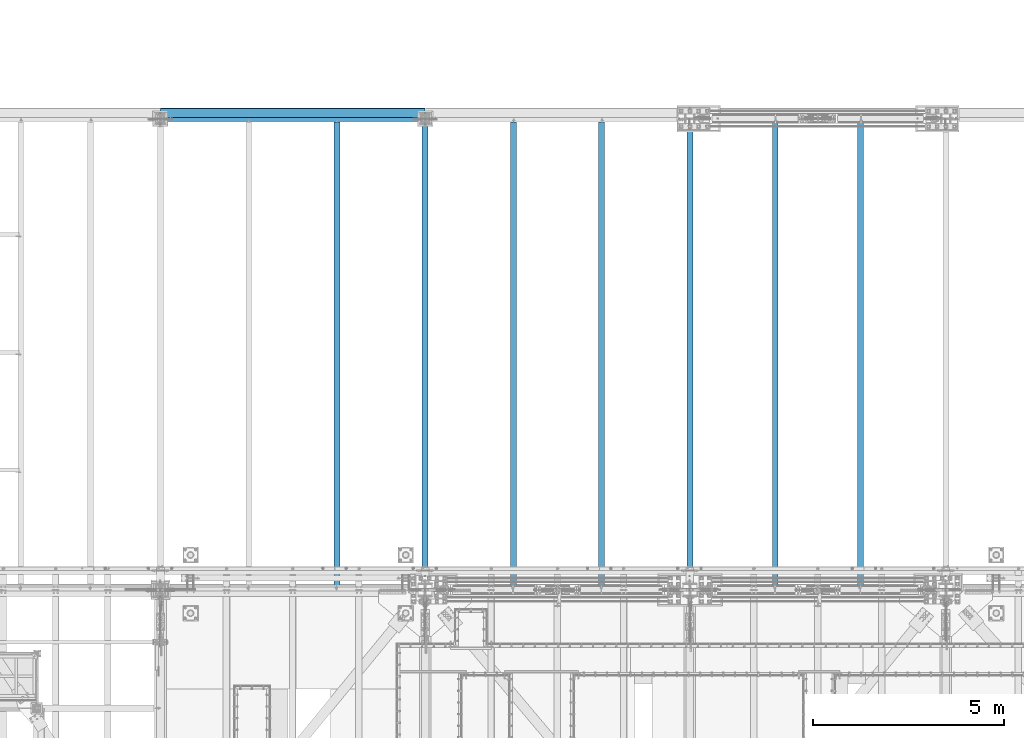
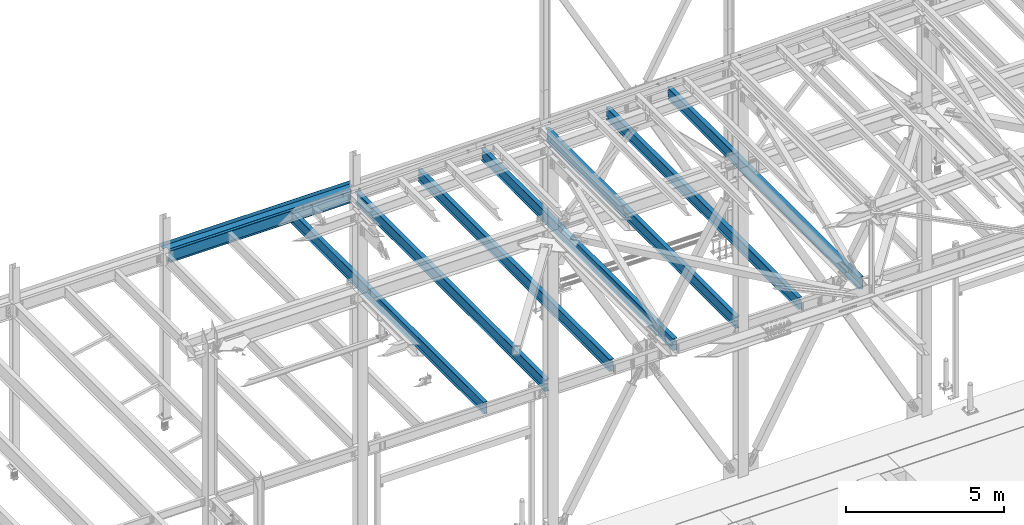
# One storey, part 1935 of 3843: 9 beams, 8 elements without a shape of their own.
"""IFC2X3 building model written with IfcOpenShell, lengths in millimetres."""

from ifc_helpers import new_model, si_unit, frame, origin_with_axes, place, context, subcontext, project, spatial, faceted_brep, material, type_object, element, aggregate, save


model = new_model("IFC2X3")

# Units and contexts
model_context = context("Model", 3, precision=1e-05, world=origin_with_axes())
body_context = subcontext(model_context, "Body", "Model", "MODEL_VIEW")
ifc_project = project(units=[si_unit("LENGTHUNIT", "METRE", prefix="MILLI"), si_unit("AREAUNIT", "SQUARE_METRE"), si_unit("VOLUMEUNIT", "CUBIC_METRE"), si_unit("MASSUNIT", "GRAM", prefix="KILO"), si_unit("TIMEUNIT", "SECOND"), si_unit("PLANEANGLEUNIT", "RADIAN"), si_unit("SOLIDANGLEUNIT", "STERADIAN"), si_unit("THERMODYNAMICTEMPERATUREUNIT", "DEGREE_CELSIUS"), si_unit("LUMINOUSINTENSITYUNIT", "LUMEN")], contexts=[model_context])

# Site, building, storey
site_placement = place(None, origin_with_axes())
site = spatial("IfcSite", under=ifc_project, at=site_placement, CompositionType="ELEMENT")
building_placement = place(site_placement, origin_with_axes())
building = spatial("IfcBuilding", under=site, at=building_placement, Name="Undefined", CompositionType="ELEMENT")
storey_placement = place(building_placement, origin_with_axes())
storey = spatial("IfcBuildingStorey", under=building, at=storey_placement, Name="Undefined", CompositionType="ELEMENT", Elevation=0.0)

# Assembly, beam
assembly_1_placement = place(storey_placement, origin_with_axes())
assembly_1 = element("IfcElementAssembly", 1, at=assembly_1_placement, inside=storey, Name="BEAM", AssemblyPlace="NOTDEFINED", PredefinedType="RIGID_FRAME")
ifc_material_1 = material(Name="STEEL/A36")
beam_type_1 = type_object("IfcBeamType", PredefinedType="NOTDEFINED")
beam_1_placement = place(assembly_1_placement, frame((45529.5, 104584.5, 36439.475), z_axis=(-1.0, 0.0, 0.0), x_axis=(0.0, 1.0, 0.0)))
beam_1 = element("IfcBeam", 2, at=beam_1_placement, type_object=beam_type_1, material=ifc_material_1, Name="BENT_PLATE", context=body_context, shape_type="Brep", body=[
    faceted_brep([(114.299996948161, -3.17499999999563, 3327.40000000001), (114.299996948161, 3.17500000000291, 3327.40000000001), (0.0, 3.17500000000291, 3327.40000000001), (0.0, -3.17500000000291, 3327.40000000001), (114.299996948161, -3.17499999999563, 3463.92499389649), (114.299996948161, 3.17500000000291, 3463.925), (0.0, -3.17500000000291, -3327.40000610351), (0.0, 3.17500000000291, -3327.40000610351), (114.299996948161, 3.17500000000291, -3327.40000610351), (114.299996948161, -3.17499999999563, -3327.40000610351), (114.299996948161, 3.17500000000291, -3463.925), (114.299996948161, -3.17499999999563, -3463.925), (253.999999999898, 3.17500000001019, -3463.925), (253.999999999942, -136.524996948334, -3463.925), (247.649999999936, -136.524996948334, -3463.925), (247.649999999892, -3.17499999999563, -3463.925), (253.999999999898, 3.17500000001019, 3463.925), (253.999999999942, -136.524996948334, 3463.925), (247.649999999936, -136.524996948334, 3463.925), (247.649999999892, -3.17499999999563, 3463.925)], [[[0, 1, 2, 3]], [[4, 5, 1, 0]], [[6, 7, 8, 9]], [[9, 8, 10, 11]], [[12, 13, 14, 15, 11, 10]], [[12, 16, 17, 13]], [[18, 14, 13, 17]], [[19, 15, 14, 18]], [[3, 6, 9, 11, 15, 19, 4, 0]], [[7, 6, 3, 2]], [[16, 12, 10, 8, 7, 2, 1, 5]], [[19, 18, 17, 16, 5, 4]]]),
])

assembly_2_placement = place(storey_placement, origin_with_axes())
assembly_2 = element("IfcElementAssembly", 3, at=assembly_2_placement, inside=storey, Name="BEAM", AssemblyPlace="NOTDEFINED", PredefinedType="RIGID_FRAME")
ifc_material_2 = material(Name="STEEL/A992")
beam_type_2 = type_object("IfcBeamType", Name="W18X40", PredefinedType="NOTDEFINED")
beam_2_placement = place(assembly_2_placement, frame((60401.2, 92214.7, 36209.2875), z_axis=(0.0, 0.0, 1.0), x_axis=(0.0, 1.0, 0.0)))
beam_2 = element("IfcBeam", 4, at=beam_2_placement, type_object=beam_type_2, material=ifc_material_2, Name="BEAM", ObjectType="W18X40", context=body_context, shape_type="Brep", body=[
    faceted_brep([(18.2562499999913, -3.96875, -201.612499999996), (18.2562499999913, 3.96875, -201.612499999996), (96.0437501907581, 3.96875, -201.612499999996), (96.0437501907581, -3.96875, -201.612499999996), (100.903829708797, 3.96875, -202.579229922587), (100.903829708797, -3.96875, -202.579229922587), (105.024006176958, 3.96875, -205.332243823061), (105.024006176958, -3.96875, -205.332243823061), (107.777020077439, 3.96875, -209.452420291214), (107.777020077439, -3.96875, -209.452420291214), (108.743750000023, 3.96875, -214.3125), (108.743750000023, -3.96875, -214.3125), (108.743750000023, -76.1999999999971, -214.312499809261), (108.743750000023, 76.1999999999971, -214.3125), (108.743750000023, 76.1999999999971, -227.012499999997), (108.743750000023, -76.1999999999971, -227.012499999997), (12234.06875, 76.1999999999971, 214.3125), (12234.06875, 3.96875, 214.3125), (108.743750000023, 3.96875, 214.3125), (108.743750000023, 76.1999999999971, 214.3125), (96.0437501907581, -3.96875, 188.912500000006), (96.0437501907581, 3.96875, 188.912500000006), (18.2562499999913, 3.96875, 188.912500000006), (18.2562499999913, -3.96875, 188.912500000006), (100.903829708797, -3.96875, 189.879229922597), (100.903829708797, 3.96875, 189.879229922597), (105.024006176958, -3.96875, 192.632243823071), (105.024006176958, 3.96875, 192.632243823071), (107.777020077439, -3.96875, 196.752420291225), (107.777020077439, 3.96875, 196.752420291225), (108.743750000023, -3.96875, 201.612499809271), (108.743750000023, 3.96875, 201.612499809271), (12234.06875, -76.1999999999971, 227.012499999997), (12234.06875, 76.1999999999971, 227.012499999997), (108.743750000023, 76.1999999999971, 227.012499999997), (108.743750000023, -76.1999999999971, 227.012499999997), (12234.06875, -76.1999999999971, 214.3125), (108.743750000023, -76.1999999999971, 214.3125), (12234.06875, -3.96875, 214.3125), (108.743750000023, -3.96875, 214.3125), (12234.06875, -3.96875, 201.612499809271), (12234.06875, 3.96875, 201.612499809271), (12235.0354799226, -3.96875, 196.752420291225), (12235.0354799226, 3.96875, 196.752420291225), (12237.7884938231, -3.96875, 192.632243823071), (12237.7884938231, 3.96875, 192.632243823071), (12241.9086702913, -3.96875, 189.879229922597), (12241.9086702913, 3.96875, 189.879229922597), (12246.7687498093, -3.96875, 188.912500000006), (12246.7687498093, 3.96875, 188.912500000006), (12326.14375, -3.96875, 188.912500000006), (12326.14375, 3.96875, 188.912500000006), (12326.14375, -3.96875, -201.612499999996), (12326.14375, 3.96875, -201.612499999996), (12246.7687498093, -3.96875, -201.612499999996), (12246.7687498093, 3.96875, -201.612499999996), (12241.9086702913, -3.96875, -202.579229922587), (12241.9086702913, 3.96875, -202.579229922587), (12237.7884938231, -3.96875, -205.332243823061), (12237.7884938231, 3.96875, -205.332243823061), (12235.0354799226, -3.96875, -209.452420291214), (12235.0354799226, 3.96875, -209.452420291214), (12234.06875, -3.96875, -214.3125), (12234.06875, 3.96875, -214.3125), (12234.06875, -76.1999999999971, -214.3125), (12234.06875, -76.1999999999971, -227.012499999997), (12234.06875, 76.1999999999971, -227.012499999997), (12234.06875, 76.1999999999971, -214.3125)], [[[0, 1, 2, 3]], [[3, 2, 4, 5]], [[5, 4, 6, 7]], [[7, 6, 8, 9]], [[9, 8, 10, 11]], [[12, 11, 10, 13, 14, 15]], [[16, 17, 18, 19]], [[20, 21, 22, 23]], [[24, 25, 21, 20]], [[26, 27, 25, 24]], [[28, 29, 27, 26]], [[30, 31, 29, 28]], [[32, 33, 34, 35]], [[36, 32, 35, 37]], [[38, 36, 37, 39]], [[35, 34, 19, 18, 31, 30, 39, 37]], [[33, 16, 19, 34]], [[32, 36, 38, 40, 41, 17, 16, 33]], [[42, 43, 41, 40]], [[44, 45, 43, 42]], [[46, 47, 45, 44]], [[48, 49, 47, 46]], [[50, 51, 49, 48]], [[51, 50, 52, 53]], [[52, 54, 55, 53]], [[56, 57, 55, 54]], [[58, 59, 57, 56]], [[60, 61, 59, 58]], [[62, 63, 61, 60]], [[64, 65, 66, 67, 63, 62]], [[65, 64, 12, 15]], [[66, 65, 15, 14]], [[67, 66, 14, 13]], [[63, 67, 13, 10]], [[6, 4, 2, 1, 22, 21, 25, 27, 29, 31, 18, 17, 41, 43, 45, 47, 49, 51, 53, 55, 57, 59, 61, 63, 10, 8]], [[23, 22, 1, 0]], [[62, 60, 58, 56, 54, 52, 50, 48, 46, 44, 42, 40, 38, 39, 30, 28, 26, 24, 20, 23, 0, 3, 5, 7, 9, 11]], [[64, 62, 11, 12]]]),
])
aggregate(assembly_2, [beam_2])

assembly_3_placement = place(storey_placement, origin_with_axes())
assembly_3 = element("IfcElementAssembly", 5, at=assembly_3_placement, inside=storey, Name="BEAM", AssemblyPlace="NOTDEFINED", PredefinedType="RIGID_FRAME")
beam_3_placement = place(assembly_3_placement, frame((58166.0, 92214.7, 36209.2875), z_axis=(0.0, 0.0, 1.0), x_axis=(0.0, 1.0, 0.0)))
beam_3 = element("IfcBeam", 6, at=beam_3_placement, type_object=beam_type_2, material=ifc_material_2, Name="BEAM", ObjectType="W18X40", context=body_context, shape_type="Brep", body=[
    faceted_brep([(18.2562499999913, -3.96875, -201.612499999996), (18.2562499999913, 3.96875, -201.612499999996), (96.0437501907581, 3.96875, -201.612499999996), (96.0437501907581, -3.96875, -201.612499999996), (100.903829708797, 3.96875, -202.579229922587), (100.903829708797, -3.96875, -202.579229922587), (105.024006176958, 3.96875, -205.332243823061), (105.024006176958, -3.96875, -205.332243823061), (107.777020077439, 3.96875, -209.452420291214), (107.777020077439, -3.96875, -209.452420291214), (108.743750000023, 3.96875, -214.3125), (108.743750000023, -3.96875, -214.3125), (108.743750000023, -76.1999999999971, -214.312499809261), (108.743750000023, 76.1999999999971, -214.3125), (108.743750000023, 76.1999999999971, -227.012499999997), (108.743750000023, -76.1999999999971, -227.012499999997), (12234.06875, 76.1999999999971, 214.3125), (12234.06875, 3.96875, 214.3125), (108.743750000023, 3.96875, 214.3125), (108.743750000023, 76.1999999999971, 214.3125), (96.0437501907581, -3.96875, 188.912500000006), (96.0437501907581, 3.96875, 188.912500000006), (18.2562499999913, 3.96875, 188.912500000006), (18.2562499999913, -3.96875, 188.912500000006), (100.903829708797, -3.96875, 189.879229922597), (100.903829708797, 3.96875, 189.879229922597), (105.024006176958, -3.96875, 192.632243823071), (105.024006176958, 3.96875, 192.632243823071), (107.777020077439, -3.96875, 196.752420291225), (107.777020077439, 3.96875, 196.752420291225), (108.743750000023, -3.96875, 201.612499809271), (108.743750000023, 3.96875, 201.612499809271), (12234.06875, -76.1999999999971, 227.012499999997), (12234.06875, 76.1999999999971, 227.012499999997), (108.743750000023, 76.1999999999971, 227.012499999997), (108.743750000023, -76.1999999999971, 227.012499999997), (12234.06875, -76.1999999999971, 214.3125), (108.743750000023, -76.1999999999971, 214.3125), (12234.06875, -3.96875, 214.3125), (108.743750000023, -3.96875, 214.3125), (12234.06875, -3.96875, 201.612499809271), (12234.06875, 3.96875, 201.612499809271), (12235.0354799226, -3.96875, 196.752420291225), (12235.0354799226, 3.96875, 196.752420291225), (12237.7884938231, -3.96875, 192.632243823071), (12237.7884938231, 3.96875, 192.632243823071), (12241.9086702913, -3.96875, 189.879229922597), (12241.9086702913, 3.96875, 189.879229922597), (12246.7687498093, -3.96875, 188.912500000006), (12246.7687498093, 3.96875, 188.912500000006), (12326.14375, -3.96875, 188.912500000006), (12326.14375, 3.96875, 188.912500000006), (12326.14375, -3.96875, -201.612499999996), (12326.14375, 3.96875, -201.612499999996), (12246.7687498093, -3.96875, -201.612499999996), (12246.7687498093, 3.96875, -201.612499999996), (12241.9086702913, -3.96875, -202.579229922587), (12241.9086702913, 3.96875, -202.579229922587), (12237.7884938231, -3.96875, -205.332243823061), (12237.7884938231, 3.96875, -205.332243823061), (12235.0354799226, -3.96875, -209.452420291214), (12235.0354799226, 3.96875, -209.452420291214), (12234.06875, -3.96875, -214.3125), (12234.06875, 3.96875, -214.3125), (12234.06875, -76.1999999999971, -214.3125), (12234.06875, -76.1999999999971, -227.012499999997), (12234.06875, 76.1999999999971, -227.012499999997), (12234.06875, 76.1999999999971, -214.3125)], [[[0, 1, 2, 3]], [[3, 2, 4, 5]], [[5, 4, 6, 7]], [[7, 6, 8, 9]], [[9, 8, 10, 11]], [[12, 11, 10, 13, 14, 15]], [[16, 17, 18, 19]], [[20, 21, 22, 23]], [[24, 25, 21, 20]], [[26, 27, 25, 24]], [[28, 29, 27, 26]], [[30, 31, 29, 28]], [[32, 33, 34, 35]], [[36, 32, 35, 37]], [[38, 36, 37, 39]], [[35, 34, 19, 18, 31, 30, 39, 37]], [[33, 16, 19, 34]], [[32, 36, 38, 40, 41, 17, 16, 33]], [[42, 43, 41, 40]], [[44, 45, 43, 42]], [[46, 47, 45, 44]], [[48, 49, 47, 46]], [[50, 51, 49, 48]], [[51, 50, 52, 53]], [[52, 54, 55, 53]], [[56, 57, 55, 54]], [[58, 59, 57, 56]], [[60, 61, 59, 58]], [[62, 63, 61, 60]], [[64, 65, 66, 67, 63, 62]], [[65, 64, 12, 15]], [[66, 65, 15, 14]], [[67, 66, 14, 13]], [[63, 67, 13, 10]], [[6, 4, 2, 1, 22, 21, 25, 27, 29, 31, 18, 17, 41, 43, 45, 47, 49, 51, 53, 55, 57, 59, 61, 63, 10, 8]], [[23, 22, 1, 0]], [[62, 60, 58, 56, 54, 52, 50, 48, 46, 44, 42, 40, 38, 39, 30, 28, 26, 24, 20, 23, 0, 3, 5, 7, 9, 11]], [[64, 62, 11, 12]]]),
])
aggregate(assembly_3, [beam_3])

assembly_4_placement = place(storey_placement, origin_with_axes())
assembly_4 = element("IfcElementAssembly", 7, at=assembly_4_placement, inside=storey, Name="BEAM", AssemblyPlace="NOTDEFINED", PredefinedType="RIGID_FRAME")
beam_4_placement = place(assembly_4_placement, frame((53619.4, 92214.7, 36209.2875), z_axis=(0.0, 0.0, 1.0), x_axis=(0.0, 1.0, 0.0)))
beam_4 = element("IfcBeam", 8, at=beam_4_placement, type_object=beam_type_2, material=ifc_material_2, Name="BEAM", ObjectType="W18X40", context=body_context, shape_type="Brep", body=[
    faceted_brep([(18.2562499999913, -3.96875, -201.612499999996), (18.2562499999913, 3.96875, -201.612499999996), (113.506250190752, 3.96875, -201.612499999996), (113.506250190752, -3.96875, -201.612499999996), (118.366329708791, 3.96875, -202.579229922587), (118.366329708791, -3.96875, -202.579229922587), (122.486506176952, 3.96875, -205.332243823061), (122.486506176952, -3.96875, -205.332243823061), (125.239520077434, 3.96875, -209.452420291214), (125.239520077434, -3.96875, -209.452420291214), (126.206250000017, 3.96875, -214.3125), (126.206250000017, -3.96875, -214.3125), (126.206250000017, -76.1999999999971, -214.312499809261), (126.206250000017, 76.1999999999971, -214.3125), (126.206250000017, 76.1999999999971, -227.012499999997), (126.206250000017, -76.1999999999971, -227.012499999997), (12251.53125, -76.1999999999971, -227.012499999997), (12251.53125, 76.1999999999971, -227.012499999997), (12251.53125, 76.1999999999971, -214.57249980927), (12251.53125, -76.1999999999971, -214.57249980927), (12251.53125, 76.1999999999971, 214.3125), (12251.53125, 3.96875, 214.3125), (126.206249999988, 3.96875, 214.3125), (126.206249999988, 76.1999999999998, 214.3125), (113.506250190752, -3.96875, 188.912500000006), (113.506250190752, 3.96875, 188.912500000006), (18.2562499999913, 3.96875, 188.912500000006), (18.2562499999913, -3.96875, 188.912500000006), (118.366329708791, -3.96875, 189.879229922597), (118.366329708791, 3.96875, 189.879229922597), (122.486506176952, -3.96875, 192.632243823071), (122.486506176952, 3.96875, 192.632243823071), (125.239520077434, -3.96875, 196.752420291225), (125.239520077434, 3.96875, 196.752420291225), (126.206250000017, -3.96875, 201.612499809271), (126.206250000017, 3.96875, 201.612499809271), (12251.53125, -76.1999999999971, 227.012499999997), (12251.53125, 76.1999999999971, 227.012499999997), (126.206249999988, 76.1999999999998, 227.012499999997), (126.206249999988, -76.1999999999998, 227.012499999997), (12251.53125, -76.1999999999971, 214.3125), (126.206249999988, -76.1999999999998, 214.3125), (12251.53125, -3.96875, 214.3125), (126.206249999988, -3.96875, 214.3125), (12251.53125, -3.96875, 214.052501487728), (12251.53125, 3.96875, 214.052501487728), (12252.4979799226, -3.96875, 209.192421969681), (12252.4979799226, 3.96875, 209.192421969681), (12255.2509938231, -3.96875, 205.072245501528), (12255.2509938231, 3.96875, 205.072245501528), (12259.3711702912, -3.96875, 202.319231601054), (12259.3711702912, 3.96875, 202.319231601054), (12264.2312498093, -3.96875, 201.352501678462), (12264.2312498093, 3.96875, 201.352501678462), (12327.73125, -3.96875, 201.352499999994), (12327.73125, 3.96875, 201.352499999994), (12327.73125, -3.96875, -201.872500000005), (12327.73125, 3.96875, -201.872500000005), (12264.2312498093, -3.96875, -201.872500000005), (12264.2312498093, 3.96875, -201.872500000005), (12259.3711702912, -3.96875, -202.839229922596), (12259.3711702912, 3.96875, -202.839229922596), (12255.2509938231, -3.96875, -205.59224382307), (12255.2509938231, 3.96875, -205.59224382307), (12252.4979799226, -3.96875, -209.712420291224), (12252.4979799226, 3.96875, -209.712420291224), (12251.5829671776, -3.96875, -214.3125), (12251.5829671776, -76.1999999999971, -214.3125), (12251.5829671776, 76.1999999999971, -214.3125), (12251.5829671776, 3.96875, -214.3125)], [[[0, 1, 2, 3]], [[3, 2, 4, 5]], [[5, 4, 6, 7]], [[7, 6, 8, 9]], [[9, 8, 10, 11]], [[12, 11, 10, 13, 14, 15]], [[16, 17, 18, 19]], [[20, 21, 22, 23]], [[24, 25, 26, 27]], [[28, 29, 25, 24]], [[30, 31, 29, 28]], [[32, 33, 31, 30]], [[34, 35, 33, 32]], [[36, 37, 38, 39]], [[40, 36, 39, 41]], [[42, 40, 41, 43]], [[39, 38, 23, 22, 35, 34, 43, 41]], [[37, 20, 23, 38]], [[36, 40, 42, 44, 45, 21, 20, 37]], [[46, 47, 45, 44]], [[48, 49, 47, 46]], [[50, 51, 49, 48]], [[52, 53, 51, 50]], [[54, 55, 53, 52]], [[55, 54, 56, 57]], [[56, 58, 59, 57]], [[60, 61, 59, 58]], [[62, 63, 61, 60]], [[64, 65, 63, 62]], [[66, 67, 19, 18, 68, 69, 65, 64]], [[16, 19, 67, 12, 15]], [[17, 16, 15, 14]], [[68, 18, 17, 14, 13]], [[69, 68, 13, 10]], [[6, 4, 2, 1, 26, 25, 29, 31, 33, 35, 22, 21, 45, 47, 49, 51, 53, 55, 57, 59, 61, 63, 65, 69, 10, 8]], [[27, 26, 1, 0]], [[66, 64, 62, 60, 58, 56, 54, 52, 50, 48, 46, 44, 42, 43, 34, 32, 30, 28, 24, 27, 0, 3, 5, 7, 9, 11]], [[67, 66, 11, 12]]]),
])
aggregate(assembly_4, [beam_4])

assembly_5_placement = place(storey_placement, origin_with_axes())
assembly_5 = element("IfcElementAssembly", 9, at=assembly_5_placement, inside=storey, Name="BEAM", AssemblyPlace="NOTDEFINED", PredefinedType="RIGID_FRAME")
beam_5_placement = place(assembly_5_placement, frame((51308.0, 92214.7, 36209.2875), z_axis=(0.0, 0.0, 1.0), x_axis=(0.0, 1.0, 0.0)))
beam_5 = element("IfcBeam", 10, at=beam_5_placement, type_object=beam_type_2, material=ifc_material_2, Name="BEAM", ObjectType="W18X40", context=body_context, shape_type="Brep", body=[
    faceted_brep([(18.2562499999913, -3.96875, -201.612499999996), (18.2562499999913, 3.96875, -201.612499999996), (113.506250190752, 3.96875, -201.612499999996), (113.506250190752, -3.96875, -201.612499999996), (118.366329708791, 3.96875, -202.579229922587), (118.366329708791, -3.96875, -202.579229922587), (122.486506176952, 3.96875, -205.332243823061), (122.486506176952, -3.96875, -205.332243823061), (125.239520077434, 3.96875, -209.452420291214), (125.239520077434, -3.96875, -209.452420291214), (126.206250000017, 3.96875, -214.3125), (126.206250000017, -3.96875, -214.3125), (126.206250000017, -76.1999999999971, -214.312499809261), (126.206250000017, 76.1999999999971, -214.3125), (126.206250000017, 76.1999999999971, -227.012499999997), (126.206250000017, -76.1999999999971, -227.012499999997), (12251.53125, -76.1999999999971, -227.012499999997), (12251.53125, 76.1999999999971, -227.012499999997), (12251.53125, 76.1999999999971, -214.57249980927), (12251.53125, -76.1999999999971, -214.57249980927), (12251.53125, 76.1999999999971, 214.3125), (12251.53125, 3.96875, 214.3125), (126.206249999988, 3.96875, 214.3125), (126.206249999988, 76.1999999999998, 214.3125), (113.506250190752, -3.96875, 188.912500000006), (113.506250190752, 3.96875, 188.912500000006), (18.2562499999913, 3.96875, 188.912500000006), (18.2562499999913, -3.96875, 188.912500000006), (118.366329708791, -3.96875, 189.879229922597), (118.366329708791, 3.96875, 189.879229922597), (122.486506176952, -3.96875, 192.632243823071), (122.486506176952, 3.96875, 192.632243823071), (125.239520077434, -3.96875, 196.752420291225), (125.239520077434, 3.96875, 196.752420291225), (126.206250000017, -3.96875, 201.612499809271), (126.206250000017, 3.96875, 201.612499809271), (12251.53125, -76.1999999999971, 227.012499999997), (12251.53125, 76.1999999999971, 227.012499999997), (126.206249999988, 76.1999999999998, 227.012499999997), (126.206249999988, -76.1999999999998, 227.012499999997), (12251.53125, -76.1999999999971, 214.3125), (126.206249999988, -76.1999999999998, 214.3125), (12251.53125, -3.96875, 214.3125), (126.206249999988, -3.96875, 214.3125), (12251.53125, -3.96875, 214.052501487728), (12251.53125, 3.96875, 214.052501487728), (12252.4979799226, -3.96875, 209.192421969681), (12252.4979799226, 3.96875, 209.192421969681), (12255.2509938231, -3.96875, 205.072245501528), (12255.2509938231, 3.96875, 205.072245501528), (12259.3711702912, -3.96875, 202.319231601054), (12259.3711702912, 3.96875, 202.319231601054), (12264.2312498093, -3.96875, 201.352501678462), (12264.2312498093, 3.96875, 201.352501678462), (12327.73125, -3.96875, 201.352499999994), (12327.73125, 3.96875, 201.352499999994), (12327.73125, -3.96875, -201.872500000005), (12327.73125, 3.96875, -201.872500000005), (12264.2312498093, -3.96875, -201.872500000005), (12264.2312498093, 3.96875, -201.872500000005), (12259.3711702912, -3.96875, -202.839229922596), (12259.3711702912, 3.96875, -202.839229922596), (12255.2509938231, -3.96875, -205.59224382307), (12255.2509938231, 3.96875, -205.59224382307), (12252.4979799226, -3.96875, -209.712420291224), (12252.4979799226, 3.96875, -209.712420291224), (12251.5829671776, -3.96875, -214.3125), (12251.5829671776, -76.1999999999971, -214.3125), (12251.5829671776, 76.1999999999971, -214.3125), (12251.5829671776, 3.96875, -214.3125)], [[[0, 1, 2, 3]], [[3, 2, 4, 5]], [[5, 4, 6, 7]], [[7, 6, 8, 9]], [[9, 8, 10, 11]], [[12, 11, 10, 13, 14, 15]], [[16, 17, 18, 19]], [[20, 21, 22, 23]], [[24, 25, 26, 27]], [[28, 29, 25, 24]], [[30, 31, 29, 28]], [[32, 33, 31, 30]], [[34, 35, 33, 32]], [[36, 37, 38, 39]], [[40, 36, 39, 41]], [[42, 40, 41, 43]], [[39, 38, 23, 22, 35, 34, 43, 41]], [[37, 20, 23, 38]], [[36, 40, 42, 44, 45, 21, 20, 37]], [[46, 47, 45, 44]], [[48, 49, 47, 46]], [[50, 51, 49, 48]], [[52, 53, 51, 50]], [[54, 55, 53, 52]], [[55, 54, 56, 57]], [[56, 58, 59, 57]], [[60, 61, 59, 58]], [[62, 63, 61, 60]], [[64, 65, 63, 62]], [[66, 67, 19, 18, 68, 69, 65, 64]], [[16, 19, 67, 12, 15]], [[17, 16, 15, 14]], [[68, 18, 17, 14, 13]], [[69, 68, 13, 10]], [[6, 4, 2, 1, 26, 25, 29, 31, 33, 35, 22, 21, 45, 47, 49, 51, 53, 55, 57, 59, 61, 63, 65, 69, 10, 8]], [[27, 26, 1, 0]], [[66, 64, 62, 60, 58, 56, 54, 52, 50, 48, 46, 44, 42, 43, 34, 32, 30, 28, 24, 27, 0, 3, 5, 7, 9, 11]], [[67, 66, 11, 12]]]),
])
aggregate(assembly_5, [beam_5])

assembly_6_placement = place(storey_placement, origin_with_axes())
assembly_6 = element("IfcElementAssembly", 11, at=assembly_6_placement, inside=storey, Name="BEAM", AssemblyPlace="NOTDEFINED", PredefinedType="RIGID_FRAME")
beam_6_placement = place(assembly_6_placement, frame((46685.2, 92214.7, 36209.2875), z_axis=(0.0, 0.0, 1.0), x_axis=(0.0, 1.0, 0.0)))
beam_6 = element("IfcBeam", 12, at=beam_6_placement, type_object=beam_type_2, material=ifc_material_2, Name="BEAM", ObjectType="W18X40", context=body_context, shape_type="Brep", body=[
    faceted_brep([(16.6687499999971, -3.96875, -201.612500000003), (16.6687499999971, 3.96875, -201.612500000003), (80.1687501907145, 3.96875, -201.612500000003), (80.1687501907145, -3.96875, -201.612500000003), (85.0288297087536, 3.96875, -202.579229922594), (85.0288297087536, -3.96875, -202.579229922594), (89.1490061769146, 3.96875, -205.332243823068), (89.1490061769146, -3.96875, -205.332243823068), (91.9020200773957, 3.96875, -209.452420291222), (91.9020200773957, -3.96875, -209.452420291222), (92.8687499999796, 3.96875, -214.3125), (92.8687499999796, -3.96875, -214.3125), (92.8687499999796, -76.1999999999971, -214.312499809268), (92.8687499999796, 76.1999999999971, -214.3125), (92.8687499999796, 76.1999999999971, -227.012499999997), (92.8687499999796, -76.1999999999971, -227.012499809534), (12251.53125, -76.1999999999971, -227.012499999997), (12251.53125, 76.1999999999971, -227.012499999997), (12251.53125, 76.1999999999971, -214.57249980927), (12251.53125, -76.1999999999971, -214.57249980927), (12251.53125, 76.1999999999971, 214.3125), (12251.53125, 3.96875, 214.3125), (92.8687499999942, 3.96875, 214.3125), (92.8687499999942, 76.1999999999971, 214.3125), (80.168750190729, -3.96875, 201.612499999996), (80.168750190729, 3.96875, 201.612499999996), (16.6687499999971, 3.96875, 201.612499999996), (16.6687499999971, -3.96875, 201.612499999996), (85.0288297087682, -3.96875, 202.579229922587), (85.0288297087682, 3.96875, 202.579229922587), (89.1490061769291, -3.96875, 205.332243823061), (89.1490061769291, 3.96875, 205.332243823061), (91.9020200774103, -3.96875, 209.452420291214), (91.9020200774103, 3.96875, 209.452420291214), (92.8687499999942, -3.96875, 214.3125), (12251.53125, -76.1999999999971, 227.012499999997), (12251.53125, 76.1999999999971, 227.012499999997), (92.8687499999942, 76.1999999999971, 227.012499999997), (92.8687499999942, -76.1999999999971, 227.01249980952), (12251.53125, -76.1999999999971, 214.3125), (92.8687499999942, -76.1999999999971, 214.3125), (12251.53125, -3.96875, 214.3125), (12251.53125, -3.96875, 214.052501487728), (12251.53125, 3.96875, 214.052501487728), (12252.4979799226, -3.96875, 209.192421969681), (12252.4979799226, 3.96875, 209.192421969681), (12255.2509938231, -3.96875, 205.072245501528), (12255.2509938231, 3.96875, 205.072245501528), (12259.3711702912, -3.96875, 202.319231601054), (12259.3711702912, 3.96875, 202.319231601054), (12264.2312498093, -3.96875, 201.352501678462), (12264.2312498093, 3.96875, 201.352501678462), (12327.73125, -3.96875, 201.352499999994), (12327.73125, 3.96875, 201.352499999994), (12327.73125, -3.96875, -201.872500000005), (12327.73125, 3.96875, -201.872500000005), (12264.2312498093, -3.96875, -201.872500000005), (12264.2312498093, 3.96875, -201.872500000005), (12259.3711702912, -3.96875, -202.839229922596), (12259.3711702912, 3.96875, -202.839229922596), (12255.2509938231, -3.96875, -205.59224382307), (12255.2509938231, 3.96875, -205.59224382307), (12252.4979799226, -3.96875, -209.712420291224), (12252.4979799226, 3.96875, -209.712420291224), (12251.5829671776, -3.96875, -214.3125), (12251.5829671776, -76.1999999999971, -214.3125), (12251.5829671776, 76.1999999999971, -214.3125), (12251.5829671776, 3.96875, -214.3125), (16.6687499999971, 3.96875, -117.887499999997), (16.6687499999971, 3.96875, 188.912499999999)], [[[0, 1, 2, 3]], [[3, 2, 4, 5]], [[5, 4, 6, 7]], [[7, 6, 8, 9]], [[9, 8, 10, 11]], [[12, 11, 10, 13, 14, 15]], [[16, 17, 18, 19]], [[20, 21, 22, 23]], [[24, 25, 26, 27]], [[28, 29, 25, 24]], [[30, 31, 29, 28]], [[32, 33, 31, 30]], [[34, 22, 33, 32]], [[35, 36, 37, 38]], [[39, 35, 38, 40]], [[41, 39, 40, 34]], [[38, 37, 23, 22, 34, 40]], [[36, 20, 23, 37]], [[35, 39, 41, 42, 43, 21, 20, 36]], [[44, 45, 43, 42]], [[46, 47, 45, 44]], [[48, 49, 47, 46]], [[50, 51, 49, 48]], [[52, 53, 51, 50]], [[53, 52, 54, 55]], [[54, 56, 57, 55]], [[58, 59, 57, 56]], [[60, 61, 59, 58]], [[62, 63, 61, 60]], [[64, 65, 19, 18, 66, 67, 63, 62]], [[16, 19, 65, 12, 15]], [[17, 16, 15, 14]], [[66, 18, 17, 14, 13]], [[67, 66, 13, 10]], [[6, 4, 2, 1, 68, 69, 26, 25, 29, 31, 33, 22, 21, 43, 45, 47, 49, 51, 53, 55, 57, 59, 61, 63, 67, 10, 8]], [[27, 26, 69, 68, 1, 0]], [[64, 62, 60, 58, 56, 54, 52, 50, 48, 46, 44, 42, 41, 34, 32, 30, 28, 24, 27, 0, 3, 5, 7, 9, 11]], [[65, 64, 11, 12]]]),
])
aggregate(assembly_6, [beam_6])

assembly_7_placement = place(storey_placement, origin_with_axes())
assembly_7 = element("IfcElementAssembly", 13, at=assembly_7_placement, inside=storey, Name="BEAM", AssemblyPlace="NOTDEFINED", PredefinedType="RIGID_FRAME")
beam_7_placement = place(assembly_7_placement, frame((55930.8, 92214.7, 36209.2875), z_axis=(0.0, 0.0, 1.0), x_axis=(0.0, 1.0, 0.0)))
beam_7 = element("IfcBeam", 14, at=beam_7_placement, type_object=beam_type_2, material=ifc_material_2, Name="BEAM", ObjectType="W18X40", context=body_context, shape_type="Brep", body=[
    faceted_brep([(190.5, -76.1999999999971, -227.012499999997), (190.5, 76.1999999999971, -227.012499999997), (12203.1125, 76.1999999999971, -227.012499999997), (12203.1125, -76.1999999999971, -227.012499999997), (190.5, -76.1999999999971, -214.3125), (190.5, -3.96875, -214.3125), (190.5, -3.96875, 214.3125), (190.5, -76.1999999999971, 214.3125), (190.5, -76.1999999999971, 227.012499999997), (190.5, 76.1999999999971, 227.012499999997), (190.5, 76.1999999999971, 214.3125), (190.5, 3.96875, 214.3125), (190.5, 3.96875, -214.3125), (190.5, 76.1999999999971, -214.3125), (12203.1125, -76.1999999999971, -214.3125), (12203.1125, -3.96875, -214.3125), (12203.1125, -3.96875, 214.3125), (12203.1125, -76.1999999999971, 214.3125), (12203.1125, -76.1999999999971, 227.012499999997), (12203.1125, 76.1999999999971, 227.012499999997), (12203.1125, 76.1999999999971, 214.3125), (12203.1125, 3.96875, 214.3125), (12203.1125, 3.96875, 189.652499999997), (12203.1125, 3.96875, -129.327499999999), (12203.1125, 3.96875, -214.3125), (12203.1125, 76.1999999999971, -214.3125)], [[[0, 1, 2, 3]], [[0, 4, 5, 6, 7, 8, 9, 10, 11, 12, 13, 1]], [[5, 4, 14, 15]], [[6, 5, 15, 16]], [[7, 6, 16, 17]], [[8, 7, 17, 18]], [[9, 8, 18, 19]], [[10, 9, 19, 20]], [[11, 10, 20, 21]], [[12, 11, 21, 22, 23, 24]], [[13, 12, 24, 25]], [[1, 13, 25, 2]], [[24, 23, 22, 21, 20, 19, 18, 17, 16, 15, 14, 3, 2, 25]], [[4, 0, 3, 14]]]),
])
aggregate(assembly_7, [beam_7])

assembly_8_placement = place(storey_placement, origin_with_axes())
assembly_8 = element("IfcElementAssembly", 15, at=assembly_8_placement, inside=storey, Name="BEAM", AssemblyPlace="NOTDEFINED", PredefinedType="RIGID_FRAME")
beam_8_placement = place(assembly_8_placement, frame((48996.6, 92214.7, 36209.2875), z_axis=(0.0, 0.0, 1.0), x_axis=(0.0, 1.0, 0.0)))
beam_8 = element("IfcBeam", 16, at=beam_8_placement, type_object=beam_type_2, material=ifc_material_2, Name="BEAM", ObjectType="W18X40", context=body_context, shape_type="Brep", body=[
    faceted_brep([(190.5, -76.1999999999971, -227.012499999997), (190.5, 76.1999999999971, -227.012499999997), (12204.7, 76.1999999999998, -227.012499999997), (12204.7, -76.1999999999998, -227.012499999997), (190.5, -76.1999999999971, -214.3125), (190.5, -3.96875, -214.3125), (190.5, -3.96875, 214.3125), (190.5, -76.1999999999971, 214.3125), (190.5, -76.1999999999971, 227.012499999997), (190.5, 76.1999999999971, 227.012499999997), (190.5, 76.1999999999971, 214.3125), (190.5, 3.96875, 214.3125), (190.5, 3.96875, -214.3125), (190.5, 76.1999999999971, -214.3125), (12204.7, -76.1999999999998, -214.3125), (12204.7, -3.96875, -214.3125), (12204.7, -3.96875, 214.3125), (12204.7, -76.1999999999998, 214.3125), (12204.7, -76.1999999999998, 227.012499999997), (12204.7, 76.1999999999998, 227.012499999997), (12204.7, 76.1999999999998, 214.3125), (12204.7, 3.96875, 214.3125), (12204.7, 3.96875, -214.3125), (12204.7, 76.1999999999998, -214.3125)], [[[0, 1, 2, 3]], [[0, 4, 5, 6, 7, 8, 9, 10, 11, 12, 13, 1]], [[5, 4, 14, 15]], [[6, 5, 15, 16]], [[7, 6, 16, 17]], [[8, 7, 17, 18]], [[9, 8, 18, 19]], [[10, 9, 19, 20]], [[11, 10, 20, 21]], [[12, 11, 21, 22]], [[13, 12, 22, 23]], [[1, 13, 23, 2]], [[22, 21, 20, 19, 18, 17, 16, 15, 14, 3, 2, 23]], [[4, 0, 3, 14]]]),
])
aggregate(assembly_8, [beam_8])

# Beam
beam_9_placement = place(assembly_1_placement, frame((42062.4, 104559.1, 36209.2875), z_axis=(0.0, 0.0, 1.0), x_axis=(1.0, 0.0, 0.0)))
beam_9 = element("IfcBeam", 17, at=beam_9_placement, type_object=beam_type_2, material=ifc_material_2, Name="BEAM", ObjectType="W18X40", context=body_context, shape_type="Brep", body=[
    faceted_brep([(139.700000000012, -76.1999999999998, -227.012499999997), (139.700000000012, 76.1999999999998, -227.012499999997), (6794.5, 76.1999999999971, -227.012499999997), (6794.5, -76.1999999999971, -227.012499999997), (139.700000000012, -76.1999999999998, -214.3125), (139.700000000012, -3.96875, -214.3125), (139.699999999997, -3.96875, -129.327499999999), (139.699999999997, -3.96875, 189.652499999997), (139.700000000012, -3.96875, 214.3125), (139.700000000012, -76.1999999999998, 214.3125), (139.700000000012, -76.1999999999998, 227.012499999997), (139.700000000012, 76.1999999999998, 227.012499999997), (139.700000000012, 76.1999999999998, 214.3125), (139.700000000012, 3.96875, 214.3125), (139.700000000012, 3.96875, -214.3125), (139.700000000012, 76.1999999999998, -214.3125), (6794.5, -76.1999999999971, -214.3125), (6794.5, -3.96875, -214.3125), (6794.5, -3.96875, -129.327499999999), (6794.5, -3.96875, 189.652499999997), (6794.5, -3.96875, 214.3125), (6794.5, -76.1999999999971, 214.3125), (6794.5, -76.1999999999971, 227.012499999997), (6794.5, 76.1999999999971, 227.012499999997), (6794.5, 76.1999999999971, 214.3125), (6794.5, 3.96875, 214.3125), (6794.5, 3.96875, -214.3125), (6794.5, 76.1999999999971, -214.3125)], [[[0, 1, 2, 3]], [[0, 4, 5, 6, 7, 8, 9, 10, 11, 12, 13, 14, 15, 1]], [[5, 4, 16, 17]], [[8, 7, 6, 5, 17, 18, 19, 20]], [[9, 8, 20, 21]], [[10, 9, 21, 22]], [[11, 10, 22, 23]], [[12, 11, 23, 24]], [[13, 12, 24, 25]], [[14, 13, 25, 26]], [[15, 14, 26, 27]], [[1, 15, 27, 2]], [[26, 25, 24, 23, 22, 21, 20, 19, 18, 17, 16, 3, 2, 27]], [[4, 0, 3, 16]]]),
])

aggregate(assembly_1, [beam_1, beam_9])

save(model, "model.ifc")
